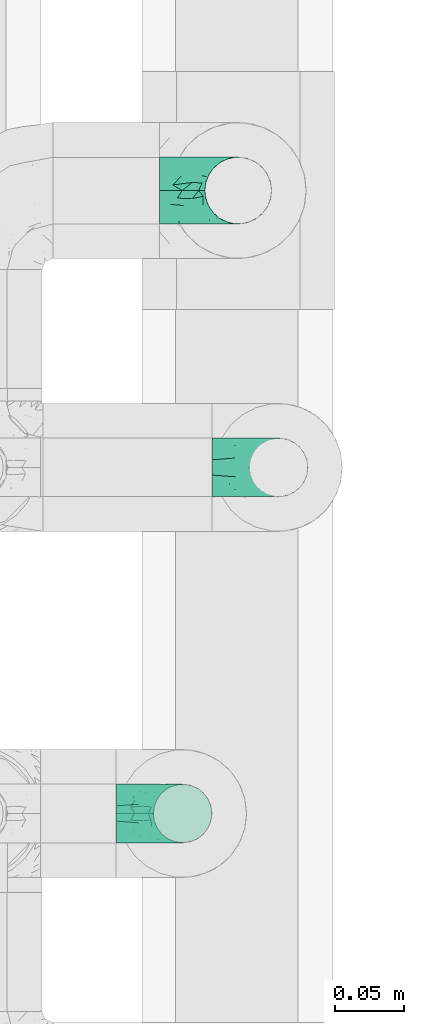
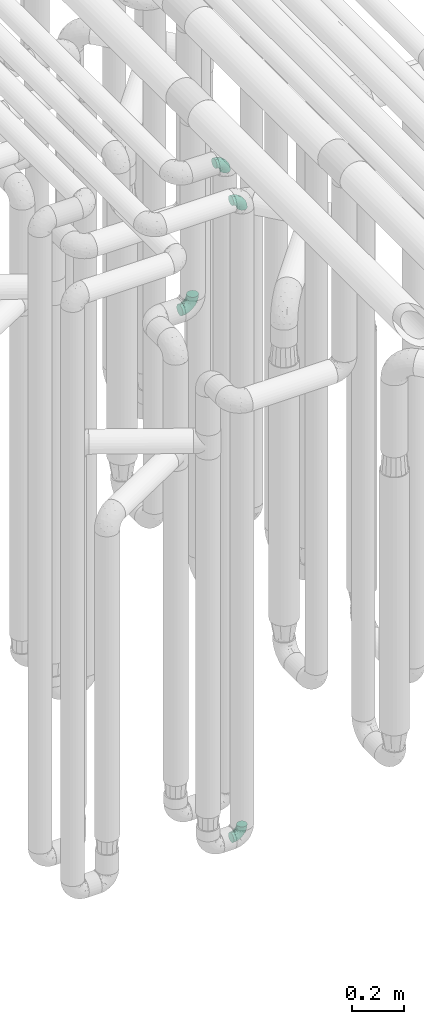
# One storey, part 612 of 827: 4 flow fittings.
"""IFC2X3 building model written with IfcOpenShell, lengths in millimetres."""

from ifc_helpers import new_model, entity, si_unit, converted_unit, derived_unit, direction, frame, origin, place, context, subcontext, project, spatial, faceted_brep, source, transform, mapped, material, type_object, type_shapes, element, save


model = new_model("IFC2X3")

# Units and contexts
model_context = context("Model", 3, precision=0.01, world=origin(), true_north=direction((6.12303176911189e-17, 1.0)))
body_context = subcontext(model_context, "Body", "Model", "MODEL_VIEW")
ifc_project = project(units=[si_unit("LENGTHUNIT", "METRE", prefix="MILLI"), si_unit("AREAUNIT", "SQUARE_METRE"), si_unit("VOLUMEUNIT", "CUBIC_METRE"), converted_unit("PLANEANGLEUNIT", "DEGREE", entity("IfcRatioMeasure", 0.0174532925199433), si_unit("PLANEANGLEUNIT", "RADIAN"), dimensions=[0, 0, 0, 0, 0, 0, 0]), si_unit("MASSUNIT", "GRAM", prefix="KILO"), derived_unit("MASSDENSITYUNIT", [(si_unit("MASSUNIT", "GRAM", prefix="KILO"), 1), (si_unit("LENGTHUNIT", "METRE"), -3)]), derived_unit("MOMENTOFINERTIAUNIT", [(si_unit("LENGTHUNIT", "METRE"), 4)]), si_unit("TIMEUNIT", "SECOND"), si_unit("FREQUENCYUNIT", "HERTZ"), si_unit("THERMODYNAMICTEMPERATUREUNIT", "DEGREE_CELSIUS"), derived_unit("THERMALTRANSMITTANCEUNIT", [(si_unit("MASSUNIT", "GRAM", prefix="KILO"), 1), (si_unit("THERMODYNAMICTEMPERATUREUNIT", "KELVIN"), -1), (si_unit("TIMEUNIT", "SECOND"), -3)]), derived_unit("VOLUMETRICFLOWRATEUNIT", [(si_unit("LENGTHUNIT", "METRE"), 3), (si_unit("TIMEUNIT", "SECOND"), -1)]), derived_unit("MASSFLOWRATEUNIT", [(si_unit("MASSUNIT", "GRAM", prefix="KILO"), 1), (si_unit("TIMEUNIT", "SECOND"), -1)]), derived_unit("ROTATIONALFREQUENCYUNIT", [(si_unit("TIMEUNIT", "SECOND"), -1)]), si_unit("ELECTRICCURRENTUNIT", "AMPERE"), si_unit("ELECTRICVOLTAGEUNIT", "VOLT"), si_unit("POWERUNIT", "WATT"), si_unit("FORCEUNIT", "NEWTON", prefix="KILO"), si_unit("ILLUMINANCEUNIT", "LUX"), si_unit("LUMINOUSFLUXUNIT", "LUMEN"), si_unit("LUMINOUSINTENSITYUNIT", "CANDELA"), derived_unit("USERDEFINED", [(si_unit("MASSUNIT", "GRAM", prefix="KILO"), -1), (si_unit("LENGTHUNIT", "METRE"), -2), (si_unit("TIMEUNIT", "SECOND"), 3), (si_unit("LUMINOUSFLUXUNIT", "LUMEN"), 1)]), derived_unit("LINEARVELOCITYUNIT", [(si_unit("LENGTHUNIT", "METRE"), 1), (si_unit("TIMEUNIT", "SECOND"), -1)]), si_unit("PRESSUREUNIT", "PASCAL"), derived_unit("USERDEFINED", [(si_unit("LENGTHUNIT", "METRE"), -2), (si_unit("MASSUNIT", "GRAM", prefix="KILO"), 1), (si_unit("TIMEUNIT", "SECOND"), -2)]), derived_unit("LINEARFORCEUNIT", [(si_unit("MASSUNIT", "GRAM", prefix="KILO"), 1), (si_unit("LENGTHUNIT", "METRE"), 1), (si_unit("TIMEUNIT", "SECOND"), -2), (si_unit("LENGTHUNIT", "METRE"), -1)]), derived_unit("PLANARFORCEUNIT", [(si_unit("MASSUNIT", "GRAM", prefix="KILO"), 1), (si_unit("LENGTHUNIT", "METRE"), 1), (si_unit("TIMEUNIT", "SECOND"), -2), (si_unit("LENGTHUNIT", "METRE"), -2)])], contexts=[model_context])

# Site, building, storey
site_placement = place(None, origin())
site = spatial("IfcSite", under=ifc_project, at=site_placement, CompositionType="ELEMENT")
building_placement = place(site_placement, origin())
building = spatial("IfcBuilding", under=site, at=building_placement, CompositionType="ELEMENT")
storey_placement = place(building_placement, frame((0.0, 0.0, 28200.0)))
storey = spatial("IfcBuildingStorey", under=building, at=storey_placement, Name="08", CompositionType="ELEMENT", Elevation=28200.0)

# Flow fittings
ifc_material = material()
pipe_fitting_type_1 = type_object("IfcPipeFittingType", Name="ADSK_1", PredefinedType="NOTDEFINED", material=ifc_material)
shared_shape_1 = source(origin(), body_context, "Body", "Brep", [
    faceted_brep([(-57.0, 12.07, -20.91), (-57.0, 6.25, -23.33), (-57.0, 0.0, -24.15), (-57.0, -6.25, -23.33), (-57.0, -12.08, -20.91), (-57.0, -17.08, -17.08), (-57.0, -20.91, -12.08), (-57.0, -23.33, -6.25), (-57.0, -24.15, 0.0), (-57.0, -23.33, 6.25), (-57.0, -20.91, 12.07), (-57.0, -17.08, 17.08), (-57.0, -12.08, 20.91), (-57.0, -6.25, 23.33), (-57.0, 0.0, 24.15), (-57.0, 6.25, 23.33), (-57.0, 12.07, 20.91), (-57.0, 17.08, 17.08), (-57.0, 20.91, 12.07), (-57.0, 23.33, 6.25), (-57.0, 24.15, 0.0), (-57.0, 23.33, -6.25), (-57.0, 20.91, -12.08), (-57.0, 17.08, -17.08), (0.0, 57.0, -24.15), (-6.25, 57.0, -23.33), (-12.07, 57.0, -20.91), (-17.08, 57.0, -17.08), (-20.91, 57.0, -12.08), (-23.33, 57.0, -6.25), (-24.15, 57.0, 0.0), (-23.33, 57.0, 6.25), (-20.91, 57.0, 12.07), (-17.08, 57.0, 17.08), (-12.07, 57.0, 20.91), (-6.25, 57.0, 23.33), (0.0, 57.0, 24.15), (6.25, 57.0, 23.33), (12.08, 57.0, 20.91), (17.08, 57.0, 17.08), (20.91, 57.0, 12.07), (23.33, 57.0, 6.25), (24.15, 57.0, 0.0), (23.33, 57.0, -6.25), (20.91, 57.0, -12.08), (17.08, 57.0, -17.08), (12.08, 57.0, -20.91), (6.25, 57.0, -23.33), (14.9, 21.14, 6.17), (13.61, 24.64, 12.48), (6.23, 8.95, 8.98), (-41.47, -21.06, 0.0), (-41.92, -18.38, 13.72), (-24.64, -13.61, 12.48), (-37.37, -13.24, 18.15), (-6.8, -4.93, 8.18), (-21.76, -15.19, 6.22), (-12.78, -9.18, 0.0), (-37.73, -20.51, 7.75), (-7.38, 7.38, 20.24), (-23.37, -4.26, 20.42), (-11.9, -3.19, 15.86), (-42.14, -8.7, 21.82), (13.24, 37.37, 18.15), (9.33, 23.53, 16.85), (4.26, 23.37, 20.42), (2.77, 10.92, 15.55), (-29.46, 0.91, 23.52), (-44.13, 20.56, 15.69), (-39.25, 26.33, 10.88), (-49.02, 22.92, 9.96), (-34.58, 23.87, 17.15), (-15.8, 6.8, 22.81), (-8.67, 20.47, 23.88), (-18.12, 12.9, 24.08), (-48.29, 14.92, 19.65), (-44.06, -2.85, 23.78), (-9.23, 48.95, 22.58), (-3.78, 42.74, 24.07), (-40.34, 4.26, 24.09), (-44.02, 26.14, 5.46), (-44.04, 9.88, 22.74), (-4.95, 16.87, 22.52), (-2.75, 1.43, 12.5), (-25.48, 40.98, 10.71), (20.51, 37.73, 7.75), (18.38, 41.92, 13.72), (8.7, 42.14, 21.82), (-25.95, -17.97, 0.0), (2.85, 44.06, 23.78), (21.06, 41.47, 0.0), (17.97, 25.95, 0.0), (-24.04, -9.27, 17.13), (-33.26, 33.26, 5.86), (-28.55, 40.57, 0.0), (-40.57, 28.55, 0.0), (-25.29, 47.19, 4.06), (-27.01, 31.1, 16.77), (-15.7, 43.95, 19.9), (-20.27, 45.22, 15.61), (-30.53, 31.98, 12.64), (-11.28, 38.33, 22.92), (-9.97, 27.88, 24.09), (-20.15, 30.26, 21.25), (-31.25, 11.75, 23.64), (-28.75, 7.23, 24.15), (-29.53, 18.06, 22.27), (-28.44, 24.21, 20.02), (-37.55, 17.7, 20.26), (-15.88, 29.25, 22.99), (-20.82, 20.82, 23.44), (-0.91, 29.46, 23.52), (-13.5, -7.67, 12.04), (1.49, 1.56, 5.16), (8.86, 10.35, 4.59), (0.38, -0.38, 0.0), (9.18, 12.78, 0.0), (-37.37, -13.24, -18.15), (8.86, 10.35, -4.59), (-45.22, 20.27, -15.61), (-43.95, 15.7, -19.9), (-38.33, 11.28, -22.92), (-48.95, 9.23, -22.58), (-47.19, 25.29, -4.06), (-33.26, 33.26, -5.86), (18.38, 41.92, -13.72), (-30.26, 20.15, -21.25), (2.85, 44.06, -23.78), (-4.26, 40.34, -24.09), (-40.98, 25.48, -10.71), (-41.92, -18.38, -13.72), (9.25, 23.5, -16.92), (4.26, 23.37, -20.42), (13.24, 37.37, -18.15), (-37.73, -20.51, -7.75), (-11.75, 31.25, -23.64), (-7.23, 28.75, -24.15), (-12.9, 18.12, -24.08), (8.7, 42.14, -21.82), (-44.06, -2.85, -23.78), (-6.8, 15.8, -22.81), (-20.47, 8.67, -23.88), (-24.64, -13.61, -12.48), (-42.74, 3.78, -24.07), (-18.06, 29.53, -22.27), (-24.21, 28.44, -20.02), (-27.88, 9.97, -24.09), (-31.1, 27.01, -16.77), (-26.14, 44.02, -5.46), (14.9, 21.14, -6.17), (20.51, 37.73, -7.75), (-9.88, 44.04, -22.74), (-20.56, 44.13, -15.69), (-21.76, -15.19, -6.22), (-13.5, -7.67, -12.04), (-24.14, -9.76, -16.74), (-11.9, -3.19, -15.86), (-14.92, 48.29, -19.65), (-23.37, -4.26, -20.42), (-0.91, 29.46, -23.52), (-26.33, 39.25, -10.88), (-23.87, 34.58, -17.15), (-42.14, -8.7, -21.82), (-22.92, 49.02, -9.96), (13.61, 24.64, -12.48), (-31.98, 30.53, -12.64), (-16.87, 4.95, -22.52), (-17.7, 37.55, -20.26), (-29.25, 15.88, -22.99), (-20.82, 20.82, -23.44), (-29.46, 0.91, -23.52), (-7.38, 7.38, -20.24), (2.77, 10.92, -15.55), (6.23, 8.95, -8.98), (-6.8, -4.93, -8.18), (-2.81, 1.41, -12.54), (1.49, 1.56, -5.16)], [[[0, 1, 2, 3, 4, 5, 6, 7, 8, 9, 10, 11, 12, 13, 14, 15, 16, 17, 18, 19, 20, 21, 22, 23]], [[24, 25, 26, 27, 28, 29, 30, 31, 32, 33, 34, 35, 36, 37, 38, 39, 40, 41, 42, 43, 44, 45, 46, 47]], [[48, 49, 50]], [[9, 8, 51]], [[52, 53, 54]], [[55, 56, 57]], [[10, 58, 52]], [[9, 58, 10]], [[59, 60, 61]], [[54, 12, 11]], [[54, 62, 12]], [[63, 39, 38]], [[64, 65, 66]], [[62, 60, 67]], [[68, 69, 70]], [[71, 69, 68]], [[72, 73, 74]], [[16, 75, 17]], [[13, 76, 14]], [[35, 77, 78]], [[14, 79, 15]], [[17, 68, 18]], [[14, 76, 79]], [[20, 19, 80]], [[70, 19, 18]], [[81, 15, 79]], [[15, 81, 16]], [[73, 72, 82]], [[66, 83, 50]], [[32, 31, 84]], [[85, 86, 49]], [[63, 87, 65]], [[56, 58, 88]], [[36, 89, 37]], [[85, 41, 40]], [[36, 35, 78]], [[90, 41, 85]], [[40, 39, 86]], [[12, 62, 13]], [[86, 85, 40]], [[48, 85, 49]], [[85, 91, 90]], [[87, 38, 37]], [[92, 60, 54]], [[80, 69, 93]], [[93, 94, 95]], [[10, 52, 11]], [[94, 96, 30]], [[97, 98, 99]], [[80, 93, 95]], [[100, 97, 84]], [[99, 98, 33]], [[101, 102, 78]], [[103, 101, 98]], [[96, 31, 30]], [[77, 98, 101]], [[77, 35, 34]], [[34, 33, 98]], [[9, 51, 58]], [[87, 63, 38]], [[104, 105, 74]], [[106, 103, 107]], [[106, 81, 104]], [[75, 68, 17]], [[108, 107, 71]], [[33, 32, 99]], [[109, 103, 110]], [[101, 109, 102]], [[89, 78, 111]], [[53, 52, 58]], [[54, 11, 52]], [[60, 62, 54]], [[88, 58, 51]], [[76, 62, 67]], [[53, 112, 92]], [[60, 59, 72]], [[39, 63, 86]], [[49, 86, 63]], [[89, 87, 37]], [[42, 41, 90]], [[111, 82, 65]], [[111, 65, 87]], [[65, 59, 66]], [[104, 81, 79]], [[75, 81, 108]], [[32, 84, 99]], [[97, 99, 84]], [[98, 97, 103]], [[106, 107, 108]], [[74, 102, 110]], [[111, 78, 102]], [[74, 110, 104]], [[74, 67, 72]], [[61, 92, 112]], [[66, 59, 61]], [[56, 53, 58]], [[66, 50, 49]], [[61, 112, 83]], [[66, 49, 64]], [[78, 89, 36]], [[87, 89, 111]], [[62, 76, 13]], [[79, 76, 67]], [[100, 93, 69]], [[96, 93, 84]], [[55, 113, 50]], [[113, 114, 50]], [[104, 79, 105]], [[106, 104, 110]], [[20, 80, 95]], [[85, 48, 91]], [[115, 114, 113]], [[116, 91, 48]], [[70, 80, 19]], [[93, 96, 94]], [[84, 31, 96]], [[103, 106, 110]], [[81, 106, 108]], [[103, 97, 107]], [[71, 107, 97]], [[71, 97, 100]], [[108, 71, 68]], [[79, 67, 105]], [[67, 74, 105]], [[115, 113, 57]], [[112, 56, 55]], [[56, 88, 57]], [[60, 72, 67]], [[82, 72, 59]], [[65, 82, 59]], [[82, 111, 73]], [[111, 102, 73]], [[102, 74, 73]], [[81, 75, 16]], [[68, 75, 108]], [[68, 70, 18]], [[80, 70, 69]], [[98, 77, 34]], [[78, 77, 101]], [[93, 100, 84]], [[71, 100, 69]], [[102, 109, 110]], [[101, 103, 109]], [[53, 92, 54]], [[61, 60, 92]], [[56, 112, 53]], [[83, 112, 55]], [[50, 83, 55]], [[61, 83, 66]], [[49, 63, 64]], [[65, 64, 63]], [[57, 113, 55]], [[114, 115, 116]], [[116, 48, 114]], [[48, 50, 114]], [[117, 5, 4]], [[116, 115, 118]], [[119, 120, 23]], [[121, 122, 120]], [[95, 123, 20]], [[0, 23, 120]], [[124, 95, 94]], [[125, 45, 44]], [[121, 120, 126]], [[24, 127, 128]], [[22, 21, 129]], [[0, 122, 1]], [[5, 117, 130]], [[131, 132, 133]], [[134, 88, 51]], [[135, 136, 137]], [[6, 5, 130]], [[46, 138, 47]], [[139, 3, 2]], [[140, 141, 137]], [[6, 134, 7]], [[134, 130, 142]], [[143, 2, 1]], [[144, 126, 145]], [[121, 146, 143]], [[147, 120, 119]], [[94, 148, 124]], [[149, 150, 91]], [[30, 29, 148]], [[151, 25, 128]], [[27, 152, 28]], [[134, 153, 88]], [[154, 155, 156]], [[27, 26, 157]], [[151, 26, 25]], [[155, 158, 156]], [[24, 47, 127]], [[1, 122, 143]], [[138, 132, 159]], [[160, 152, 161]], [[24, 128, 25]], [[46, 133, 138]], [[162, 117, 4]], [[148, 160, 124]], [[152, 160, 163]], [[154, 142, 155]], [[45, 125, 133]], [[133, 46, 45]], [[125, 164, 133]], [[51, 7, 134]], [[42, 90, 43]], [[165, 147, 129]], [[153, 134, 142]], [[43, 150, 44]], [[162, 4, 3]], [[141, 140, 166]], [[117, 162, 158]], [[163, 29, 28]], [[43, 90, 150]], [[123, 21, 20]], [[144, 151, 135]], [[157, 152, 27]], [[167, 145, 161]], [[23, 22, 119]], [[168, 126, 169]], [[121, 168, 146]], [[139, 143, 170]], [[142, 130, 117]], [[8, 7, 51]], [[134, 6, 130]], [[139, 162, 3]], [[170, 166, 158]], [[170, 158, 162]], [[158, 171, 156]], [[44, 150, 125]], [[91, 150, 90]], [[164, 125, 150]], [[132, 138, 133]], [[127, 138, 159]], [[131, 164, 172]], [[132, 171, 140]], [[135, 151, 128]], [[157, 151, 167]], [[22, 129, 119]], [[147, 119, 129]], [[120, 147, 126]], [[144, 145, 167]], [[137, 146, 169]], [[170, 143, 146]], [[137, 169, 135]], [[137, 159, 140]], [[171, 172, 156]], [[173, 174, 175]], [[156, 175, 154]], [[174, 57, 153]], [[132, 172, 171]], [[172, 164, 173]], [[143, 139, 2]], [[162, 139, 170]], [[138, 127, 47]], [[128, 127, 159]], [[165, 124, 160]], [[123, 124, 129]], [[149, 173, 164]], [[176, 174, 173]], [[135, 128, 136]], [[144, 135, 169]], [[150, 149, 164]], [[176, 118, 115]], [[149, 91, 116]], [[30, 148, 94]], [[163, 148, 29]], [[124, 123, 95]], [[129, 21, 123]], [[126, 144, 169]], [[151, 144, 167]], [[126, 147, 145]], [[161, 145, 147]], [[161, 147, 165]], [[167, 161, 152]], [[128, 159, 136]], [[159, 137, 136]], [[154, 153, 142]], [[132, 140, 159]], [[174, 176, 57]], [[57, 88, 153]], [[166, 140, 171]], [[158, 166, 171]], [[166, 170, 141]], [[170, 146, 141]], [[146, 137, 141]], [[151, 157, 26]], [[152, 157, 167]], [[152, 163, 28]], [[148, 163, 160]], [[120, 122, 0]], [[143, 122, 121]], [[124, 165, 129]], [[161, 165, 160]], [[146, 168, 169]], [[121, 126, 168]], [[142, 117, 155]], [[158, 155, 117]], [[175, 156, 172]], [[153, 154, 174]], [[173, 175, 172]], [[174, 154, 175]], [[164, 131, 133]], [[172, 132, 131]], [[176, 173, 118]], [[57, 176, 115]], [[173, 149, 118]], [[149, 116, 118]]]),
])
type_shapes(pipe_fitting_type_1, [shared_shape_1])
flow_fitting_placement = place(storey_placement, frame((35918.97, 10806.2, 2600.0), z_axis=(0.0, -1.0, 0.0), x_axis=(1.0, 0.0, 0.0)))
element("IfcFlowFitting", 1, at=flow_fitting_placement, inside=storey, type_object=pipe_fitting_type_1, material=ifc_material, Name="ADSK_1", ObjectType="ADSK_1", context=body_context, shape_type="MappedRepresentation", body=[
    mapped(shared_shape_1, transform((0.0, 0.0, 0.0), scale=1.0)),
])
pipe_fitting_type_2 = type_object("IfcPipeFittingType", Name="ADSK_1", PredefinedType="NOTDEFINED", material=ifc_material)
shared_shape_2 = source(origin(), body_context, "Body", "Brep", [
    faceted_brep([(-48.0, 10.6, -18.36), (-48.0, 5.49, -20.48), (-48.0, 0.0, -21.2), (-48.0, -5.49, -20.48), (-48.0, -10.6, -18.36), (-48.0, -14.99, -14.99), (-48.0, -18.36, -10.6), (-48.0, -20.48, -5.49), (-48.0, -21.2, 0.0), (-48.0, -20.48, 5.49), (-48.0, -18.36, 10.6), (-48.0, -14.99, 14.99), (-48.0, -10.6, 18.36), (-48.0, -5.49, 20.48), (-48.0, 0.0, 21.2), (-48.0, 5.49, 20.48), (-48.0, 10.6, 18.36), (-48.0, 14.99, 14.99), (-48.0, 18.36, 10.6), (-48.0, 20.48, 5.49), (-48.0, 21.2, 0.0), (-48.0, 20.48, -5.49), (-48.0, 18.36, -10.6), (-48.0, 14.99, -14.99), (0.0, 48.0, -21.2), (-5.49, 48.0, -20.48), (-10.6, 48.0, -18.36), (-14.99, 48.0, -14.99), (-18.36, 48.0, -10.6), (-20.48, 48.0, -5.49), (-21.2, 48.0, 0.0), (-20.48, 48.0, 5.49), (-18.36, 48.0, 10.6), (-14.99, 48.0, 14.99), (-10.6, 48.0, 18.36), (-5.49, 48.0, 20.48), (0.0, 48.0, 21.2), (5.49, 48.0, 20.48), (10.6, 48.0, 18.36), (14.99, 48.0, 14.99), (18.36, 48.0, 10.6), (20.48, 48.0, 5.49), (21.2, 48.0, 0.0), (20.48, 48.0, -5.49), (18.36, 48.0, -10.6), (14.99, 48.0, -14.99), (10.6, 48.0, -18.36), (5.49, 48.0, -20.48), (-35.25, -16.22, 12.01), (-34.76, -18.57, 0.0), (-20.87, -12.37, 10.9), (-31.49, -11.78, 15.9), (-37.0, -2.58, 20.86), (-33.89, 3.62, 21.15), (-31.81, -18.14, 6.76), (-5.78, 5.78, 17.67), (-19.42, -4.1, 17.86), (-9.6, -3.39, 13.73), (-35.44, -7.73, 19.13), (11.78, 31.49, 15.9), (-5.93, -5.46, 6.95), (-18.45, -13.78, 5.46), (-10.29, -8.43, 0.0), (-24.6, 0.55, 20.62), (-37.28, 17.94, 13.81), (-33.38, 22.85, 9.59), (-41.46, 20.06, 8.75), (-29.51, 20.45, 15.16), (-15.04, 10.79, 21.13), (-7.08, 16.98, 20.93), (-8.39, 23.51, 21.15), (-40.86, 13.03, 17.26), (-8.05, 41.26, 19.83), (-3.21, 35.97, 21.14), (8.53, 19.66, 14.74), (4.1, 19.42, 17.86), (-37.72, 22.66, 4.78), (-37.07, 8.58, 19.98), (-13.0, 5.43, 19.97), (-3.78, 13.93, 19.7), (3.02, 8.69, 13.43), (-2.27, -0.05, 10.65), (6.22, 6.99, 7.09), (-22.25, 34.6, 9.45), (18.14, 31.81, 6.76), (16.22, 35.25, 12.01), (12.37, 20.87, 10.9), (7.73, 35.44, 19.13), (-21.52, -15.93, 0.0), (2.58, 37.0, 20.86), (18.57, 34.76, 0.0), (13.78, 18.45, 5.46), (15.93, 21.52, 0.0), (-20.03, -8.54, 14.9), (-28.6, 28.6, 5.16), (-24.79, 34.6, 0.0), (-34.6, 24.79, 0.0), (-22.81, 37.41, 4.68), (-23.36, 26.33, 14.79), (-13.68, 37.05, 17.49), (-17.72, 38.12, 13.73), (-26.25, 27.3, 11.24), (-9.71, 32.34, 20.14), (-17.26, 25.6, 18.71), (-26.33, 9.99, 20.77), (-24.06, 6.05, 21.2), (-25.02, 15.46, 19.56), (-24.3, 20.72, 17.57), (-31.95, 15.23, 17.8), (-13.53, 24.7, 20.21), (-17.6, 17.6, 20.6), (-0.55, 24.6, 20.62), (-11.41, -7.48, 10.43), (0.93, -0.93, 0.0), (8.43, 10.29, 0.0), (-11.41, -7.48, -10.43), (-20.1, -8.84, -14.66), (-9.6, -3.39, -13.73), (7.73, 35.44, -19.13), (4.1, 19.42, -17.86), (-0.55, 24.6, -20.62), (-38.12, 17.72, -13.73), (-37.05, 13.68, -17.49), (-32.34, 9.71, -20.14), (-41.26, 8.05, -19.83), (-37.41, 22.81, -4.68), (-23.51, 8.39, -21.15), (-35.97, 3.21, -21.14), (-28.6, 28.6, -5.16), (-31.81, -18.14, -6.76), (-18.45, -13.78, -5.46), (-25.6, 17.26, -18.71), (-19.42, -4.1, -17.86), (-17.94, 37.28, -13.81), (-22.85, 33.38, -9.59), (-20.06, 41.46, -8.75), (-31.49, -11.78, -15.9), (-35.25, -16.22, -12.01), (8.53, 19.66, -14.74), (11.78, 31.49, -15.9), (-9.99, 26.33, -20.77), (-6.05, 24.06, -21.2), (-10.79, 15.04, -21.13), (-37.0, -2.58, -20.86), (-16.98, 7.08, -20.93), (-5.43, 13.0, -19.97), (-13.93, 3.78, -19.7), (-20.87, -12.37, -10.9), (-26.33, 23.36, -14.79), (-22.66, 37.72, -4.78), (13.78, 18.45, -5.46), (18.14, 31.81, -6.76), (-15.46, 25.02, -19.56), (-20.72, 24.3, -17.57), (16.22, 35.25, -12.01), (-13.03, 40.86, -17.26), (-8.58, 37.07, -19.98), (2.58, 37.0, -20.86), (-3.62, 33.89, -21.15), (-34.6, 22.25, -9.45), (6.22, 6.99, -7.09), (-20.45, 29.51, -15.16), (-35.44, -7.73, -19.13), (12.37, 20.87, -10.9), (-27.3, 26.25, -11.24), (-15.23, 31.95, -17.8), (-24.7, 13.53, -20.21), (-24.6, 0.55, -20.62), (-5.78, 5.78, -17.67), (-17.6, 17.6, -20.6), (3.02, 8.69, -13.43), (-5.93, -5.46, -6.95), (-2.27, -0.05, -10.65)], [[[0, 1, 2, 3, 4, 5, 6, 7, 8, 9, 10, 11, 12, 13, 14, 15, 16, 17, 18, 19, 20, 21, 22, 23]], [[24, 25, 26, 27, 28, 29, 30, 31, 32, 33, 34, 35, 36, 37, 38, 39, 40, 41, 42, 43, 44, 45, 46, 47]], [[10, 48, 11]], [[9, 8, 49]], [[48, 50, 51]], [[14, 52, 53]], [[10, 54, 48]], [[9, 54, 10]], [[55, 56, 57]], [[51, 12, 11]], [[51, 58, 12]], [[59, 39, 38]], [[60, 61, 62]], [[58, 56, 63]], [[64, 65, 66]], [[67, 65, 64]], [[68, 69, 70]], [[16, 71, 17]], [[13, 52, 14]], [[35, 72, 73]], [[14, 53, 15]], [[17, 64, 18]], [[74, 59, 75]], [[20, 19, 76]], [[66, 19, 18]], [[77, 15, 53]], [[15, 77, 16]], [[69, 78, 79]], [[80, 81, 82]], [[32, 31, 83]], [[84, 85, 86]], [[59, 87, 75]], [[61, 54, 88]], [[36, 89, 37]], [[84, 41, 40]], [[36, 35, 73]], [[90, 41, 84]], [[40, 39, 85]], [[12, 58, 13]], [[85, 84, 40]], [[91, 84, 86]], [[84, 92, 90]], [[87, 38, 37]], [[93, 56, 51]], [[65, 94, 76]], [[94, 95, 96]], [[84, 91, 92]], [[95, 97, 30]], [[98, 99, 100]], [[76, 94, 96]], [[101, 98, 83]], [[100, 99, 33]], [[102, 70, 73]], [[103, 102, 99]], [[94, 97, 95]], [[72, 99, 102]], [[72, 35, 34]], [[34, 33, 99]], [[9, 49, 54]], [[87, 59, 38]], [[104, 105, 68]], [[106, 103, 107]], [[106, 77, 104]], [[71, 64, 17]], [[108, 107, 67]], [[33, 32, 100]], [[109, 103, 110]], [[102, 109, 70]], [[89, 73, 111]], [[50, 48, 54]], [[51, 11, 48]], [[56, 58, 51]], [[88, 54, 49]], [[52, 58, 63]], [[50, 112, 93]], [[56, 55, 78]], [[39, 59, 85]], [[86, 85, 59]], [[89, 87, 37]], [[42, 41, 90]], [[111, 79, 75]], [[111, 75, 87]], [[75, 55, 80]], [[104, 77, 53]], [[71, 77, 108]], [[32, 83, 100]], [[98, 100, 83]], [[99, 98, 103]], [[106, 107, 108]], [[68, 70, 110]], [[111, 73, 70]], [[68, 110, 104]], [[68, 63, 78]], [[57, 93, 112]], [[80, 55, 57]], [[61, 50, 54]], [[80, 82, 86]], [[81, 57, 112]], [[74, 86, 59]], [[60, 113, 82]], [[82, 114, 91]], [[101, 94, 65]], [[97, 94, 83]], [[73, 89, 36]], [[87, 89, 111]], [[58, 52, 13]], [[53, 52, 63]], [[104, 53, 105]], [[106, 104, 110]], [[20, 76, 96]], [[76, 19, 66]], [[103, 106, 110]], [[77, 106, 108]], [[103, 98, 107]], [[67, 107, 98]], [[67, 98, 101]], [[108, 67, 64]], [[53, 63, 105]], [[63, 68, 105]], [[83, 31, 97]], [[30, 97, 31]], [[62, 113, 60]], [[112, 61, 60]], [[61, 88, 62]], [[86, 82, 91]], [[56, 78, 63]], [[114, 82, 113]], [[114, 92, 91]], [[79, 78, 55]], [[75, 79, 55]], [[69, 79, 111]], [[70, 69, 111]], [[78, 69, 68]], [[77, 71, 16]], [[64, 71, 108]], [[64, 66, 18]], [[76, 66, 65]], [[99, 72, 34]], [[73, 72, 102]], [[94, 101, 83]], [[67, 101, 65]], [[75, 80, 74]], [[80, 86, 74]], [[70, 109, 110]], [[102, 103, 109]], [[50, 93, 51]], [[57, 56, 93]], [[61, 112, 50]], [[81, 112, 60]], [[82, 81, 60]], [[80, 57, 81]], [[115, 116, 117]], [[118, 119, 120]], [[121, 122, 23]], [[123, 124, 122]], [[96, 125, 20]], [[123, 126, 127]], [[128, 96, 95]], [[129, 130, 88]], [[123, 122, 131]], [[116, 132, 117]], [[133, 134, 135]], [[0, 124, 1]], [[5, 136, 137]], [[138, 119, 139]], [[129, 88, 49]], [[140, 141, 142]], [[6, 5, 137]], [[46, 118, 47]], [[143, 3, 2]], [[144, 145, 146]], [[6, 129, 7]], [[129, 137, 147]], [[127, 2, 1]], [[148, 122, 121]], [[128, 125, 96]], [[134, 128, 149]], [[95, 149, 128]], [[150, 151, 92]], [[30, 29, 149]], [[152, 131, 153]], [[27, 133, 28]], [[154, 45, 44]], [[136, 5, 4]], [[27, 26, 155]], [[156, 26, 25]], [[24, 157, 158]], [[24, 47, 157]], [[22, 21, 159]], [[160, 150, 114]], [[134, 133, 161]], [[142, 144, 126]], [[46, 139, 118]], [[162, 136, 4]], [[156, 25, 158]], [[1, 124, 127]], [[115, 147, 116]], [[45, 154, 139]], [[139, 46, 45]], [[154, 163, 139]], [[162, 4, 3]], [[42, 90, 43]], [[130, 129, 147]], [[49, 7, 129]], [[43, 151, 44]], [[0, 23, 122]], [[24, 158, 25]], [[136, 162, 132]], [[135, 29, 28]], [[43, 90, 151]], [[164, 148, 159]], [[152, 156, 140]], [[155, 133, 27]], [[165, 153, 161]], [[23, 22, 121]], [[123, 131, 166]], [[123, 166, 126]], [[143, 127, 167]], [[147, 137, 136]], [[8, 7, 49]], [[129, 6, 137]], [[143, 162, 3]], [[167, 146, 132]], [[167, 132, 162]], [[132, 168, 117]], [[44, 151, 154]], [[92, 151, 90]], [[163, 154, 151]], [[119, 118, 139]], [[157, 118, 120]], [[138, 139, 163]], [[119, 168, 145]], [[140, 156, 158]], [[155, 156, 165]], [[22, 159, 121]], [[148, 121, 159]], [[122, 148, 131]], [[152, 153, 165]], [[142, 126, 169]], [[167, 127, 126]], [[142, 169, 140]], [[142, 120, 145]], [[168, 170, 117]], [[160, 171, 172]], [[115, 172, 171]], [[171, 62, 130]], [[119, 170, 168]], [[170, 163, 160]], [[150, 163, 151]], [[113, 171, 160]], [[164, 128, 134]], [[125, 128, 159]], [[127, 143, 2]], [[162, 143, 167]], [[118, 157, 47]], [[158, 157, 120]], [[140, 158, 141]], [[152, 140, 169]], [[30, 149, 95]], [[149, 29, 135]], [[131, 152, 169]], [[156, 152, 165]], [[131, 148, 153]], [[161, 153, 148]], [[161, 148, 164]], [[165, 161, 133]], [[158, 120, 141]], [[120, 142, 141]], [[159, 21, 125]], [[20, 125, 21]], [[115, 130, 147]], [[114, 113, 160]], [[62, 171, 113]], [[62, 88, 130]], [[160, 163, 150]], [[150, 92, 114]], [[119, 145, 120]], [[146, 145, 168]], [[132, 146, 168]], [[144, 146, 167]], [[126, 144, 167]], [[145, 144, 142]], [[156, 155, 26]], [[133, 155, 165]], [[133, 135, 28]], [[149, 135, 134]], [[122, 124, 0]], [[127, 124, 123]], [[128, 164, 159]], [[161, 164, 134]], [[163, 170, 138]], [[170, 119, 138]], [[131, 169, 166]], [[126, 166, 169]], [[147, 136, 116]], [[132, 116, 136]], [[172, 115, 117]], [[130, 115, 171]], [[117, 170, 172]], [[160, 172, 170]]]),
])
type_shapes(pipe_fitting_type_2, [shared_shape_2])
for number, where, z_axis, x_axis, name in (
    (2, (35878.78, 10356.17, 400.0), (0.0, -1.0, 0.0), (1.0, 0.0, 0.0), "ADSK_1"),
    (3, (35878.78, 10356.17, 3400.0), (0.0, -1.0, 0.0), (0.0, 0.0, 1.0), "ADSK_1"),
    (4, (35948.05, 10606.2, 3400.0), (0.0, -1.0, 0.0), (0.0, 0.0, 1.0), "ADSK_1"),
):
    element("IfcFlowFitting", number, at=place(storey_placement, frame(where, z_axis=z_axis, x_axis=x_axis)), inside=storey, type_object=pipe_fitting_type_2, material=ifc_material, Name=name, ObjectType="ADSK_1", context=body_context, shape_type="MappedRepresentation", body=[
        mapped(shared_shape_2, transform((0.0, 0.0, 0.0), scale=1.0)),
    ])

save(model, "model.ifc")
